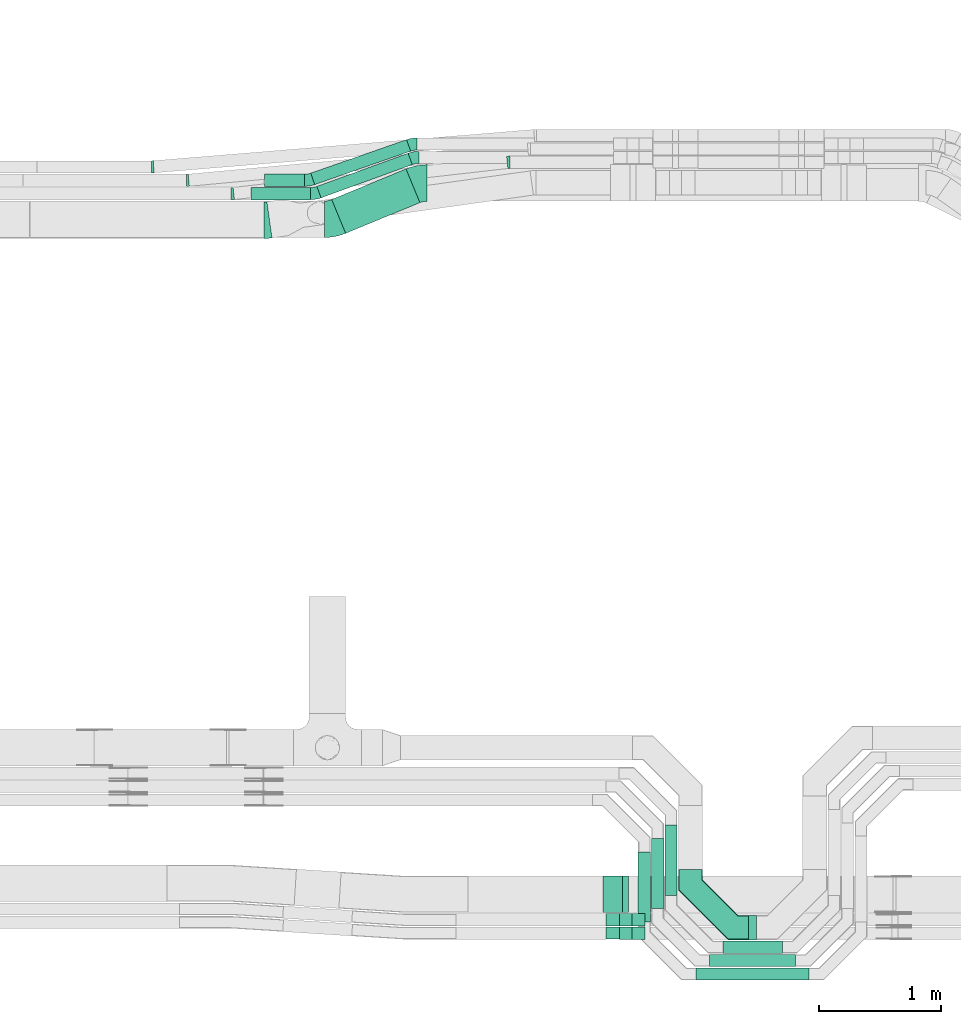
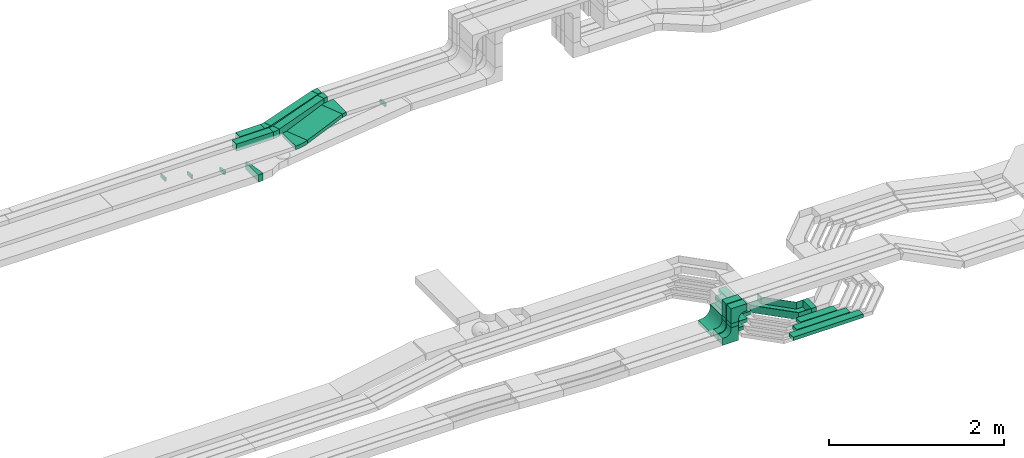
# One storey, part 13 of 32: 17 flow fittings, 15 flow segments.
"""IFC2X3 building model written with IfcOpenShell, lengths in millimetres."""

from ifc_helpers import new_model, entity, si_unit, converted_unit, derived_unit, direction, frame, frame_2d, origin, origin_2d_with_axis, place, context, subcontext, project, spatial, polyline, circle_curve, parameter, trimmed, segment, composite_curve, rectangle, outline, extrude, faceted_brep, source, transform, mapped, material, type_object, type_shapes, element, save


model = new_model("IFC2X3")

# Units and contexts
model_context = context("Model", 3, precision=0.01, world=origin(), true_north=direction((6.12303176911189e-17, 1.0)))
body_context = subcontext(model_context, "Body", "Model", "MODEL_VIEW")
ifc_project = project(units=[si_unit("LENGTHUNIT", "METRE", prefix="MILLI"), si_unit("AREAUNIT", "SQUARE_METRE"), si_unit("VOLUMEUNIT", "CUBIC_METRE"), converted_unit("PLANEANGLEUNIT", "DEGREE", entity("IfcRatioMeasure", 0.0174532925199433), si_unit("PLANEANGLEUNIT", "RADIAN"), dimensions=[0, 0, 0, 0, 0, 0, 0]), si_unit("MASSUNIT", "GRAM", prefix="KILO"), derived_unit("MASSDENSITYUNIT", [(si_unit("MASSUNIT", "GRAM", prefix="KILO"), 1), (si_unit("LENGTHUNIT", "METRE"), -3)]), derived_unit("MOMENTOFINERTIAUNIT", [(si_unit("LENGTHUNIT", "METRE"), 4)]), si_unit("TIMEUNIT", "SECOND"), si_unit("FREQUENCYUNIT", "HERTZ"), si_unit("THERMODYNAMICTEMPERATUREUNIT", "DEGREE_CELSIUS"), derived_unit("THERMALTRANSMITTANCEUNIT", [(si_unit("MASSUNIT", "GRAM", prefix="KILO"), 1), (si_unit("THERMODYNAMICTEMPERATUREUNIT", "KELVIN"), -1), (si_unit("TIMEUNIT", "SECOND"), -3)]), derived_unit("VOLUMETRICFLOWRATEUNIT", [(si_unit("LENGTHUNIT", "METRE"), 3), (si_unit("TIMEUNIT", "SECOND"), -1)]), derived_unit("MASSFLOWRATEUNIT", [(si_unit("MASSUNIT", "GRAM", prefix="KILO"), 1), (si_unit("TIMEUNIT", "SECOND"), -1)]), derived_unit("ROTATIONALFREQUENCYUNIT", [(si_unit("TIMEUNIT", "SECOND"), -1)]), si_unit("ELECTRICCURRENTUNIT", "AMPERE"), si_unit("ELECTRICVOLTAGEUNIT", "VOLT"), si_unit("POWERUNIT", "WATT"), si_unit("FORCEUNIT", "NEWTON", prefix="KILO"), si_unit("ILLUMINANCEUNIT", "LUX"), si_unit("LUMINOUSFLUXUNIT", "LUMEN"), si_unit("LUMINOUSINTENSITYUNIT", "CANDELA"), derived_unit("USERDEFINED", [(si_unit("MASSUNIT", "GRAM", prefix="KILO"), -1), (si_unit("LENGTHUNIT", "METRE"), -2), (si_unit("TIMEUNIT", "SECOND"), 3), (si_unit("LUMINOUSFLUXUNIT", "LUMEN"), 1)]), derived_unit("LINEARVELOCITYUNIT", [(si_unit("LENGTHUNIT", "METRE"), 1), (si_unit("TIMEUNIT", "SECOND"), -1)]), si_unit("PRESSUREUNIT", "PASCAL"), derived_unit("USERDEFINED", [(si_unit("LENGTHUNIT", "METRE"), -2), (si_unit("MASSUNIT", "GRAM", prefix="KILO"), 1), (si_unit("TIMEUNIT", "SECOND"), -2)]), derived_unit("LINEARFORCEUNIT", [(si_unit("MASSUNIT", "GRAM", prefix="KILO"), 1), (si_unit("LENGTHUNIT", "METRE"), 1), (si_unit("TIMEUNIT", "SECOND"), -2), (si_unit("LENGTHUNIT", "METRE"), -1)]), derived_unit("PLANARFORCEUNIT", [(si_unit("MASSUNIT", "GRAM", prefix="KILO"), 1), (si_unit("LENGTHUNIT", "METRE"), 1), (si_unit("TIMEUNIT", "SECOND"), -2), (si_unit("LENGTHUNIT", "METRE"), -2)])], contexts=[model_context])

# Site, building, storey
site_placement = place(None, origin())
site = spatial("IfcSite", under=ifc_project, at=site_placement, CompositionType="ELEMENT")
building_placement = place(site_placement, origin())
building = spatial("IfcBuilding", under=site, at=building_placement, CompositionType="ELEMENT")
storey_placement = place(building_placement, frame((0.0, 0.0, 8100.0)))
storey = spatial("IfcBuildingStorey", under=building, at=storey_placement, CompositionType="ELEMENT", Elevation=8100.0)

# Flow segments
cable_carrier_segment_type = type_object("IfcCableCarrierSegmentType", PredefinedType="CABLETRAYSEGMENT")
flow_segment_1_placement = place(storey_placement, frame((27126.5, 14216.7, 2840.02)))
element("IfcFlowSegment", 1, at=flow_segment_1_placement, inside=storey, type_object=cable_carrier_segment_type, context=body_context, shape_type="SweptSolid", body=[
    extrude(rectangle(XDim=659.52836889801, YDim=299.999999999997, at=origin_2d_with_axis()), frame((362.05, 264.47, 0.0), z_axis=(0.0, 0.0, 1.0), x_axis=(-0.924356472691493, -0.381529961331139, 0.0)), (0.0, 0.0, 1.0), 50.0000000000016),
])
flow_segment_2_placement = place(storey_placement, frame((27004.82, 14507.73, 2840.0)))
element("IfcFlowSegment", 2, at=flow_segment_2_placement, inside=storey, type_object=cable_carrier_segment_type, context=body_context, shape_type="SweptSolid", body=[
    extrude(rectangle(XDim=797.077067377563, YDim=99.9999999999991, at=origin_2d_with_axis()), frame((391.57, 183.44, 0.0), z_axis=(0.0, 0.0, 1.0), x_axis=(-0.939555537595458, -0.342396541708164, 0.0)), (0.0, 0.0, 1.0), 99.9999999999989),
])
flow_segment_3_placement = place(storey_placement, frame((26954.31, 14616.58, 2840.0)))
element("IfcFlowSegment", 3, at=flow_segment_3_placement, inside=storey, type_object=cable_carrier_segment_type, context=body_context, shape_type="SweptSolid", body=[
    extrude(rectangle(XDim=833.426581075166, YDim=100.000000000001, at=origin_2d_with_axis()), frame((409.9, 184.58, 0.0), z_axis=(0.0, 0.0, 1.0), x_axis=(-0.944095363050818, -0.329672482118153, 0.0)), (0.0, 0.0, 1.0), 99.9999999999989),
])
flow_segment_4_placement = place(storey_placement, frame((26464.1, 14492.28, 2840.0)))
element("IfcFlowSegment", 4, at=flow_segment_4_placement, inside=storey, type_object=cable_carrier_segment_type, context=body_context, shape_type="SweptSolid", body=[
    extrude(rectangle(XDim=487.423298539587, YDim=99.9999999999989, at=origin_2d_with_axis()), frame((243.71, 50.0, 0.0)), (0.0, 0.0, 1.0), 99.9999999999989),
])
flow_segment_5_placement = place(storey_placement, frame((26574.1, 14602.28, 2840.0)))
element("IfcFlowSegment", 5, at=flow_segment_5_placement, inside=storey, type_object=cable_carrier_segment_type, context=body_context, shape_type="SweptSolid", body=[
    extrude(rectangle(XDim=328.814741691739, YDim=99.9999999999989, at=origin_2d_with_axis()), frame((164.41, 50.0, 0.0)), (0.0, 0.0, 1.0), 99.9999999999989),
])
flow_segment_6_placement = place(storey_placement, frame((30337.47, 8308.02, 2800.0)))
element("IfcFlowSegment", 6, at=flow_segment_6_placement, inside=storey, type_object=cable_carrier_segment_type, context=body_context, shape_type="SweptSolid", body=[
    extrude(rectangle(XDim=487.314922946357, YDim=100.000000000001, at=origin_2d_with_axis()), frame((243.66, 50.0, 0.0)), (0.0, 0.0, 1.0), 50.0000000000016),
])
flow_segment_7_placement = place(storey_placement, frame((30227.95, 8198.49, 2800.0)))
element("IfcFlowSegment", 7, at=flow_segment_7_placement, inside=storey, type_object=cable_carrier_segment_type, context=body_context, shape_type="SweptSolid", body=[
    extrude(rectangle(XDim=706.36163665698, YDim=99.9999999999989, at=origin_2d_with_axis()), frame((353.18, 50.0, 0.0)), (0.0, 0.0, 1.0), 50.0000000000016),
])
flow_segment_8_placement = place(storey_placement, frame((30117.95, 8088.49, 2800.0)))
element("IfcFlowSegment", 8, at=flow_segment_8_placement, inside=storey, type_object=cable_carrier_segment_type, context=body_context, shape_type="SweptSolid", body=[
    extrude(rectangle(XDim=926.361636657043, YDim=99.9999999999989, at=origin_2d_with_axis()), frame((463.18, 50.0, 0.0)), (0.0, 0.0, 1.0), 50.0000000000016),
])
flow_segment_9_placement = place(storey_placement, frame((30547.47, 8418.02, 2800.0)))
element("IfcFlowSegment", 9, at=flow_segment_9_placement, inside=storey, type_object=cable_carrier_segment_type, context=body_context, shape_type="SweptSolid", body=[
    extrude(rectangle(XDim=67.3149229463092, YDim=200.0, at=origin_2d_with_axis()), frame((33.66, 100.0, 0.0)), (0.0, 0.0, 1.0), 99.9999999999989),
])
flow_segment_10_placement = place(storey_placement, frame((29489.46, 8422.45, 2999.32)))
element("IfcFlowSegment", 10, at=flow_segment_10_placement, inside=storey, type_object=cable_carrier_segment_type, context=body_context, shape_type="SweptSolid", body=[
    extrude(rectangle(XDim=100.000000000001, YDim=100.000000000003, at=origin_2d_with_axis()), frame((50.0, 50.0, 0.0), z_axis=(0.0, 0.0, 1.0), x_axis=(0.0, 1.0, 0.0)), (0.0, 0.0, 1.0), 54.9788826680355),
])
flow_segment_11_placement = place(storey_placement, frame((29489.46, 8532.45, 2999.67)))
element("IfcFlowSegment", 11, at=flow_segment_11_placement, inside=storey, type_object=cable_carrier_segment_type, context=body_context, shape_type="SweptSolid", body=[
    extrude(rectangle(XDim=100.000000000001, YDim=100.000000000003, at=origin_2d_with_axis()), frame((50.0, 50.0, 0.0), z_axis=(0.0, 0.0, 1.0), x_axis=(0.0, 1.0, 0.0)), (0.0, 0.0, 1.0), 55.3479418970819),
])
flow_segment_12_placement = place(storey_placement, frame((29514.46, 8642.05, 3000.02)))
element("IfcFlowSegment", 12, at=flow_segment_12_placement, inside=storey, type_object=cable_carrier_segment_type, context=body_context, shape_type="SweptSolid", body=[
    extrude(rectangle(XDim=299.999999999999, YDim=49.9999999999973, at=origin_2d_with_axis()), frame((25.0, 150.0, 0.0), z_axis=(0.0, 0.0, 1.0), x_axis=(0.0, 1.0, 0.0)), (0.0, 0.0, 1.0), 5.00181141795619),
])
flow_segment_13_placement = place(storey_placement, frame((29861.47, 8784.02, 2800.0)))
element("IfcFlowSegment", 13, at=flow_segment_13_placement, inside=storey, type_object=cable_carrier_segment_type, context=body_context, shape_type="SweptSolid", body=[
    extrude(rectangle(XDim=574.980554870002, YDim=100.000000000003, at=origin_2d_with_axis()), frame((50.0, 287.49, 0.0), z_axis=(0.0, 0.0, 1.0), x_axis=(0.0, 1.0, 0.0)), (0.0, 0.0, 1.0), 50.0000000000016),
])
flow_segment_14_placement = place(storey_placement, frame((29751.95, 8674.49, 2800.0)))
element("IfcFlowSegment", 14, at=flow_segment_14_placement, inside=storey, type_object=cable_carrier_segment_type, context=body_context, shape_type="SweptSolid", body=[
    extrude(rectangle(XDim=574.980554869993, YDim=100.000000000003, at=origin_2d_with_axis()), frame((50.0, 287.49, 0.0), z_axis=(0.0, 0.0, 1.0), x_axis=(0.0, 1.0, 0.0)), (0.0, 0.0, 1.0), 50.0000000000016),
])
flow_segment_15_placement = place(storey_placement, frame((29641.95, 8564.49, 2800.0)))
element("IfcFlowSegment", 15, at=flow_segment_15_placement, inside=storey, type_object=cable_carrier_segment_type, context=body_context, shape_type="SweptSolid", body=[
    extrude(rectangle(XDim=574.98055487001, YDim=100.000000000003, at=origin_2d_with_axis()), frame((50.0, 287.49, 0.0), z_axis=(0.0, 0.0, 1.0), x_axis=(0.0, 1.0, 0.0)), (0.0, 0.0, 1.0), 50.0000000000016),
])

# Flow fittings
ifc_material = material()
cable_carrier_fitting_type_1 = type_object("IfcCableCarrierFittingType", Name="470_DKC_G5_Sheet horizontal bend:-", PredefinedType="NOTDEFINED", material=ifc_material)
shared_shape_1 = source(origin(), body_context, "Body", "Brep", [
    faceted_brep([(-476.0, -100.0, -50.0), (-476.0, -100.0, 50.0), (-476.0, -95.0, 50.0), (-476.0, -95.0, -45.0), (-476.0, 95.0, -45.0), (-476.0, 95.0, 50.0), (-476.0, 100.0, 50.0), (-476.0, 100.0, -50.0), (100.0, 476.0, -50.0), (-100.0, 476.0, -50.0), (-100.0, 476.0, 50.0), (-95.0, 476.0, 50.0), (-95.0, 476.0, -45.0), (95.0, 476.0, -45.0), (95.0, 476.0, 50.0), (100.0, 476.0, 50.0), (-308.58, -100.0, -50.0), (-308.58, -100.0, 50.0), (100.0, 308.58, 50.0), (95.0, 310.65, 50.0), (-310.65, -95.0, 50.0), (-310.65, -95.0, -45.0), (95.0, 310.65, -45.0), (-95.0, 389.35, -45.0), (-389.35, 95.0, -45.0), (-389.35, 95.0, 50.0), (-95.0, 389.35, 50.0), (-100.0, 391.42, 50.0), (-391.42, 100.0, 50.0), (-391.42, 100.0, -50.0), (-100.0, 391.42, -50.0), (100.0, 308.58, -50.0)], [[[0, 1, 2, 3, 4, 5, 6, 7]], [[8, 9, 10, 11, 12, 13, 14, 15]], [[1, 0, 16, 17]], [[2, 1, 17, 18, 15, 14, 19, 20]], [[3, 2, 20, 21]], [[4, 3, 21, 22, 13, 12, 23, 24]], [[5, 4, 24, 25]], [[6, 5, 25, 26, 11, 10, 27, 28]], [[7, 6, 28, 29]], [[0, 7, 29, 30, 9, 8, 31, 16]], [[17, 16, 31, 18]], [[21, 20, 19, 22]], [[25, 24, 23, 26]], [[29, 28, 27, 30]], [[18, 31, 8, 15]], [[22, 19, 14, 13]], [[26, 23, 12, 11]], [[30, 27, 10, 9]]]),
])
type_shapes(cable_carrier_fitting_type_1, [shared_shape_1])
flow_fitting_1_placement = place(storey_placement, frame((30071.47, 8518.02, 2850.0), z_axis=(0.0, 0.0, 1.0), x_axis=(0.0, -1.0, 0.0)))
element("IfcFlowFitting", 16, at=flow_fitting_1_placement, inside=storey, type_object=cable_carrier_fitting_type_1, material=ifc_material, Name="470_DKC_G5_Sheet horizontal bend:-", ObjectType="470_DKC_G5_Sheet horizontal bend:-", context=body_context, shape_type="MappedRepresentation", body=[
    mapped(shared_shape_1, transform((0.0, 0.0, 0.0), scale=1.0)),
])
cable_carrier_fitting_type_2 = type_object("IfcCableCarrierFittingType", Name="470_DKC_S5_CDV 90 external vertical angle:-", PredefinedType="NOTDEFINED", material=ifc_material)
shared_shape_2 = source(origin(), body_context, "Body", "SweptSolid", [
    extrude(outline(composite_curve([segment(polyline([(65.71, 14.29), (95.71, 14.29)]), True, "CONTINUOUS"), segment(polyline([(95.71, 14.29), (95.71, 114.29)]), True, "CONTINUOUS"), segment(polyline([(95.71, 114.29), (-114.29, 114.29)]), True, "CONTINUOUS"), segment(polyline([(-114.29, 114.29), (-114.29, -95.71)]), True, "CONTINUOUS"), segment(polyline([(-114.29, -95.71), (-14.29, -95.71)]), True, "CONTINUOUS"), segment(polyline([(-14.29, -95.71), (-14.29, -65.71)]), True, "CONTINUOUS"), segment(trimmed(circle_curve(frame_2d((65.71, -65.71), x_axis=(-1.0, 0.0)), 80.0), [parameter(270.0)], [parameter(2.54444374517082e-13)], True, "PARAMETER"), False, "CONTINUOUS")], self_intersect=False)), frame((-64.29, 64.29, -49.0), z_axis=(0.0, 0.0, 1.0), x_axis=(-1.0, 0.0, 0.0)), (0.0, 0.0, 1.0), 99.0000000000002),
])
type_shapes(cable_carrier_fitting_type_2, [shared_shape_2])
for number, where, z_axis, x_axis, name in (
    (17, (29539.46, 8472.45, 3214.3), (0.0, -1.0, 0.0), (-1.0, 0.0, 0.0), "470_DKC_S5_90 external vertical angle"),
    (18, (29539.46, 8582.45, 3215.02), (0.0, 1.0, 0.0), (0.0, 0.0, 1.0), "470_DKC_S5_90 external vertical angle"),
):
    element("IfcFlowFitting", number, at=place(storey_placement, frame(where, z_axis=z_axis, x_axis=x_axis)), inside=storey, type_object=cable_carrier_fitting_type_2, material=ifc_material, Name=name, ObjectType="470_DKC_S5_CDV 90 external vertical angle:-", context=body_context, shape_type="MappedRepresentation", body=[
        mapped(shared_shape_2, transform((0.0, 0.0, 0.0), scale=1.0)),
    ])
cable_carrier_fitting_type_3 = type_object("IfcCableCarrierFittingType", Name="470_DKC_S5_CDV 90 external vertical angle:-", PredefinedType="NOTDEFINED", material=ifc_material)
type_shapes(cable_carrier_fitting_type_3, [shared_shape_2])
for number, where, z_axis, x_axis, name in (
    (19, (29539.46, 8582.45, 2839.67), (0.0, 1.0, 0.0), (0.0, 0.0, -1.0), "470_DKC_S5_90 external vertical angle"),
    (20, (29539.46, 8472.45, 2839.32), (0.0, 1.0, 0.0), (0.0, 0.0, -1.0), "470_DKC_S5_90 external vertical angle"),
):
    element("IfcFlowFitting", number, at=place(storey_placement, frame(where, z_axis=z_axis, x_axis=x_axis)), inside=storey, type_object=cable_carrier_fitting_type_3, material=ifc_material, Name=name, ObjectType="470_DKC_S5_CDV 90 external vertical angle:-", context=body_context, shape_type="MappedRepresentation", body=[
        mapped(shared_shape_2, transform((0.0, 0.0, 0.0), scale=1.0)),
    ])
cable_carrier_fitting_type_4 = type_object("IfcCableCarrierFittingType", Name="470_DKC_S5_CDV 90 external vertical angle:-", PredefinedType="NOTDEFINED", material=ifc_material)
shared_shape_3 = source(origin(), body_context, "Body", "SweptSolid", [
    extrude(outline(composite_curve([segment(polyline([(80.0, 50.0), (110.0, 50.0)]), True, "CONTINUOUS"), segment(polyline([(110.0, 50.0), (110.0, 100.0)]), True, "CONTINUOUS"), segment(polyline([(110.0, 100.0), (-100.0, 100.0)]), True, "CONTINUOUS"), segment(polyline([(-100.0, 100.0), (-100.0, -110.0)]), True, "CONTINUOUS"), segment(polyline([(-100.0, -110.0), (-50.0, -110.0)]), True, "CONTINUOUS"), segment(polyline([(-50.0, -110.0), (-50.0, -80.0)]), True, "CONTINUOUS"), segment(trimmed(circle_curve(frame_2d((80.0, -80.0), x_axis=(-1.0, 0.0)), 130.0), [parameter(270.0)], [parameter(2.54444374517082e-13)], True, "PARAMETER"), False, "CONTINUOUS")], self_intersect=False)), frame((-75.0, 75.0, -149.0), z_axis=(0.0, 0.0, 1.0), x_axis=(-1.0, 0.0, 0.0)), (0.0, 0.0, 1.0), 299.0),
])
type_shapes(cable_carrier_fitting_type_4, [shared_shape_3])
flow_fitting_2_placement = place(storey_placement, frame((29539.46, 8792.05, 2815.02), z_axis=(0.0, 1.0, 0.0), x_axis=(0.0, 0.0, -1.0)))
element("IfcFlowFitting", 21, at=flow_fitting_2_placement, inside=storey, type_object=cable_carrier_fitting_type_4, material=ifc_material, Name="470_DKC_S5_90 external vertical angle", ObjectType="470_DKC_S5_CDV 90 external vertical angle:-", context=body_context, shape_type="MappedRepresentation", body=[
    mapped(shared_shape_3, transform((0.0, 0.0, 0.0), scale=1.0)),
])
cable_carrier_fitting_type_5 = type_object("IfcCableCarrierFittingType", Name="470_DKC_S5_Variable Angle Elbow 0-45:-", PredefinedType="NOTDEFINED", material=ifc_material)
shared_shape_4 = source(origin(), body_context, "Body", "SweptSolid", [
    extrude(outline(composite_curve([segment(polyline([(-12.29, -50.67), (-11.29, -50.67)]), True, "CONTINUOUS"), segment(trimmed(circle_curve(frame_2d((-11.29, 199.33), x_axis=(0.0, -1.0)), 250.0), [parameter(0.0)], [parameter(6.48278712085122)], True, "PARAMETER"), True, "CONTINUOUS"), segment(polyline([(16.94, -49.07), (17.93, -48.96)]), True, "CONTINUOUS"), segment(polyline([(17.93, -48.96), (6.64, 50.4)]), True, "CONTINUOUS"), segment(polyline([(6.64, 50.4), (5.65, 50.29)]), True, "CONTINUOUS"), segment(trimmed(circle_curve(frame_2d((-11.29, 199.33), x_axis=(0.0, -1.0)), 150.0), [parameter(0.0)], [parameter(6.48278712085122)], True, "PARAMETER"), False, "CONTINUOUS"), segment(polyline([(-11.29, 49.33), (-12.29, 49.33)]), True, "CONTINUOUS"), segment(polyline([(-12.29, 49.33), (-12.29, -50.67)]), True, "CONTINUOUS")], self_intersect=False)), frame((-0.04, 0.67, -25.0)), (0.0, 0.0, 1.0), 50.0000000000002),
])
type_shapes(cable_carrier_fitting_type_5, [shared_shape_4])
flow_fitting_3_placement = place(storey_placement, frame((28579.36, 14800.06, 2590.34), z_axis=(0.0, 0.0, 1.0), x_axis=(-1.0, 0.0, 0.0)))
element("IfcFlowFitting", 22, at=flow_fitting_3_placement, inside=storey, type_object=cable_carrier_fitting_type_5, material=ifc_material, Name="470_DKC_S5_Variable Angle Elbow 0-45:-", ObjectType="470_DKC_S5_Variable Angle Elbow 0-45:-", context=body_context, shape_type="MappedRepresentation", body=[
    mapped(shared_shape_4, transform((0.0, 0.0, 0.0), scale=1.0)),
])
flow_fitting_4_placement = place(storey_placement, frame((26310.81, 14542.28, 2590.34)))
element("IfcFlowFitting", 23, at=flow_fitting_4_placement, inside=storey, type_object=cable_carrier_fitting_type_5, material=ifc_material, Name="470_DKC_S5_Variable Angle Elbow 0-45:-", ObjectType="470_DKC_S5_Variable Angle Elbow 0-45:-", context=body_context, shape_type="MappedRepresentation", body=[
    mapped(shared_shape_4, transform((0.0, 0.0, 0.0), scale=1.0)),
])
cable_carrier_fitting_type_6 = type_object("IfcCableCarrierFittingType", Name="470_DKC_S5_Variable Angle Elbow 0-45:-", PredefinedType="NOTDEFINED", material=ifc_material)
shared_shape_5 = source(origin(), body_context, "Body", "SweptSolid", [
    extrude(outline(composite_curve([segment(polyline([(-10.16, -50.44), (-9.16, -50.44)]), True, "CONTINUOUS"), segment(trimmed(circle_curve(frame_2d((-9.16, 199.56), x_axis=(0.0, -1.0)), 250.0), [parameter(0.0)], [parameter(5.25373463552036)], True, "PARAMETER"), True, "CONTINUOUS"), segment(polyline([(13.74, -49.39), (14.73, -49.3)]), True, "CONTINUOUS"), segment(polyline([(14.73, -49.3), (5.58, 50.28)]), True, "CONTINUOUS"), segment(polyline([(5.58, 50.28), (4.58, 50.19)]), True, "CONTINUOUS"), segment(trimmed(circle_curve(frame_2d((-9.16, 199.56), x_axis=(0.0, -1.0)), 150.0), [parameter(0.0)], [parameter(5.25373463552036)], True, "PARAMETER"), False, "CONTINUOUS"), segment(polyline([(-9.16, 49.56), (-10.16, 49.56)]), True, "CONTINUOUS"), segment(polyline([(-10.16, 49.56), (-10.16, -50.44)]), True, "CONTINUOUS")], self_intersect=False)), frame((-0.02, 0.44, -25.0)), (0.0, 0.0, 1.0), 50.0000000000002),
])
type_shapes(cable_carrier_fitting_type_6, [shared_shape_5])
flow_fitting_5_placement = place(storey_placement, frame((25943.41, 14652.28, 2595.0)))
element("IfcFlowFitting", 24, at=flow_fitting_5_placement, inside=storey, type_object=cable_carrier_fitting_type_6, material=ifc_material, Name="470_DKC_S5_Variable Angle Elbow 0-45:-", ObjectType="470_DKC_S5_Variable Angle Elbow 0-45:-", context=body_context, shape_type="MappedRepresentation", body=[
    mapped(shared_shape_5, transform((0.0, 0.0, 0.0), scale=1.0)),
])
cable_carrier_fitting_type_7 = type_object("IfcCableCarrierFittingType", Name="470_DKC_S5_Variable Angle Elbow 0-45:-", PredefinedType="NOTDEFINED", material=ifc_material)
shared_shape_6 = source(origin(), body_context, "Body", "SweptSolid", [
    extrude(outline(composite_curve([segment(polyline([(-9.18, -50.36), (-8.18, -50.36)]), True, "CONTINUOUS"), segment(trimmed(circle_curve(frame_2d((-8.18, 199.64), x_axis=(0.0, -1.0)), 250.0), [parameter(0.0)], [parameter(4.69132642007995)], True, "PARAMETER"), True, "CONTINUOUS"), segment(polyline([(12.27, -49.52), (13.27, -49.44)]), True, "CONTINUOUS"), segment(polyline([(13.27, -49.44), (5.09, 50.23)]), True, "CONTINUOUS"), segment(polyline([(5.09, 50.23), (4.09, 50.15)]), True, "CONTINUOUS"), segment(trimmed(circle_curve(frame_2d((-8.18, 199.64), x_axis=(0.0, -1.0)), 150.0), [parameter(0.0)], [parameter(4.69132642007995)], True, "PARAMETER"), False, "CONTINUOUS"), segment(polyline([(-8.18, 49.64), (-9.18, 49.64)]), True, "CONTINUOUS"), segment(polyline([(-9.18, 49.64), (-9.18, -50.36)]), True, "CONTINUOUS")], self_intersect=False)), frame((-0.01, 0.36, -25.0)), (0.0, 0.0, 1.0), 50.0000000000002),
])
type_shapes(cable_carrier_fitting_type_7, [shared_shape_6])
flow_fitting_6_placement = place(storey_placement, frame((25656.77, 14762.28, 2595.0)))
element("IfcFlowFitting", 25, at=flow_fitting_6_placement, inside=storey, type_object=cable_carrier_fitting_type_7, material=ifc_material, Name="470_DKC_S5_Variable Angle Elbow 0-45:-", ObjectType="470_DKC_S5_Variable Angle Elbow 0-45:-", context=body_context, shape_type="MappedRepresentation", body=[
    mapped(shared_shape_6, transform((0.0, 0.0, 0.0), scale=1.0)),
])
cable_carrier_fitting_type_8 = type_object("IfcCableCarrierFittingType", Name="470_DKC_S5_Variable Angle Elbow 0-45:-", PredefinedType="NOTDEFINED", material=ifc_material)
shared_shape_7 = source(origin(), body_context, "Body", "SweptSolid", [
    extrude(outline(composite_curve([segment(polyline([(-58.21, -161.44), (-57.21, -161.44)]), True, "CONTINUOUS"), segment(trimmed(circle_curve(frame_2d((-57.21, 288.56), x_axis=(0.0, -1.0)), 450.0), [parameter(0.0)], [parameter(22.4284842268306)], True, "PARAMETER"), True, "CONTINUOUS"), segment(polyline([(114.48, -127.4), (115.4, -127.02)]), True, "CONTINUOUS"), segment(polyline([(115.4, -127.02), (0.94, 150.29)]), True, "CONTINUOUS"), segment(polyline([(0.94, 150.29), (0.02, 149.9)]), True, "CONTINUOUS"), segment(trimmed(circle_curve(frame_2d((-57.21, 288.56), x_axis=(0.0, -1.0)), 150.0), [parameter(0.0)], [parameter(22.4284842268306)], True, "PARAMETER"), False, "CONTINUOUS"), segment(polyline([(-57.21, 138.56), (-58.21, 138.56)]), True, "CONTINUOUS"), segment(polyline([(-58.21, 138.56), (-58.21, -161.44)]), True, "CONTINUOUS")], self_intersect=False)), frame((-2.27, 11.44, -25.0)), (0.0, 0.0, 1.0), 49.9999999999992),
])
type_shapes(cable_carrier_fitting_type_8, [shared_shape_7])
flow_fitting_7_placement = place(storey_placement, frame((27849.28, 14630.06, 2865.02), z_axis=(0.0, 0.0, 1.0), x_axis=(-1.0, 0.0, 0.0)))
element("IfcFlowFitting", 26, at=flow_fitting_7_placement, inside=storey, type_object=cable_carrier_fitting_type_8, material=ifc_material, Name="470_DKC_S5_Variable Angle Elbow 0-45:-", ObjectType="470_DKC_S5_Variable Angle Elbow 0-45:-", context=body_context, shape_type="MappedRepresentation", body=[
    mapped(shared_shape_7, transform((0.0, 0.0, 0.0), scale=1.0)),
])
flow_fitting_8_placement = place(storey_placement, frame((27127.83, 14332.28, 2865.02)))
element("IfcFlowFitting", 27, at=flow_fitting_8_placement, inside=storey, type_object=cable_carrier_fitting_type_8, material=ifc_material, Name="470_DKC_S5_Variable Angle Elbow 0-45:-", ObjectType="470_DKC_S5_Variable Angle Elbow 0-45:-", context=body_context, shape_type="MappedRepresentation", body=[
    mapped(shared_shape_7, transform((0.0, 0.0, 0.0), scale=1.0)),
])
cable_carrier_fitting_type_9 = type_object("IfcCableCarrierFittingType", Name="470_DKC_S5_Variable Angle Elbow 0-45:-", PredefinedType="NOTDEFINED", material=ifc_material)
shared_shape_8 = source(origin(), body_context, "Body", "SweptSolid", [
    extrude(outline(composite_curve([segment(polyline([(-35.22, -56.13), (-34.22, -56.13)]), True, "CONTINUOUS"), segment(trimmed(circle_curve(frame_2d((-34.22, 193.87), x_axis=(0.0, -1.0)), 250.0), [parameter(0.0)], [parameter(20.0229517728653)], True, "PARAMETER"), True, "CONTINUOUS"), segment(polyline([(51.37, -41.02), (52.31, -40.68)]), True, "CONTINUOUS"), segment(polyline([(52.31, -40.68), (18.07, 53.28)]), True, "CONTINUOUS"), segment(polyline([(18.07, 53.28), (17.13, 52.94)]), True, "CONTINUOUS"), segment(trimmed(circle_curve(frame_2d((-34.22, 193.87), x_axis=(0.0, -1.0)), 150.0), [parameter(0.0)], [parameter(20.0229517728653)], True, "PARAMETER"), False, "CONTINUOUS"), segment(polyline([(-34.22, 43.87), (-35.22, 43.87)]), True, "CONTINUOUS"), segment(polyline([(-35.22, 43.87), (-35.22, -56.13)]), True, "CONTINUOUS")], self_intersect=False)), frame((-1.08, 6.13, -50.0)), (0.0, 0.0, 1.0), 100.0),
])
type_shapes(cable_carrier_fitting_type_9, [shared_shape_8])
flow_fitting_9_placement = place(storey_placement, frame((27804.95, 14840.06, 2890.0), z_axis=(0.0, 0.0, 1.0), x_axis=(-1.0, 0.0, 0.0)))
element("IfcFlowFitting", 28, at=flow_fitting_9_placement, inside=storey, type_object=cable_carrier_fitting_type_9, material=ifc_material, Name="470_DKC_S5_Variable Angle Elbow 0-45:-", ObjectType="470_DKC_S5_Variable Angle Elbow 0-45:-", context=body_context, shape_type="MappedRepresentation", body=[
    mapped(shared_shape_8, transform((0.0, 0.0, 0.0), scale=1.0)),
])
flow_fitting_10_placement = place(storey_placement, frame((26987.83, 14542.28, 2890.0)))
element("IfcFlowFitting", 29, at=flow_fitting_10_placement, inside=storey, type_object=cable_carrier_fitting_type_9, material=ifc_material, Name="470_DKC_S5_Variable Angle Elbow 0-45:-", ObjectType="470_DKC_S5_Variable Angle Elbow 0-45:-", context=body_context, shape_type="MappedRepresentation", body=[
    mapped(shared_shape_8, transform((0.0, 0.0, 0.0), scale=1.0)),
])
cable_carrier_fitting_type_10 = type_object("IfcCableCarrierFittingType", Name="470_DKC_S5_Variable Angle Elbow 0-45:-", PredefinedType="NOTDEFINED", material=ifc_material)
shared_shape_9 = source(origin(), body_context, "Body", "SweptSolid", [
    extrude(outline(composite_curve([segment(polyline([(-33.95, -55.67), (-32.95, -55.67)]), True, "CONTINUOUS"), segment(trimmed(circle_curve(frame_2d((-32.95, 194.33), x_axis=(0.0, -1.0)), 250.0), [parameter(0.0)], [parameter(19.2488977013697)], True, "PARAMETER"), True, "CONTINUOUS"), segment(polyline([(49.46, -41.7), (50.41, -41.37)]), True, "CONTINUOUS"), segment(polyline([(50.41, -41.37), (17.44, 53.04)]), True, "CONTINUOUS"), segment(polyline([(17.44, 53.04), (16.5, 52.71)]), True, "CONTINUOUS"), segment(trimmed(circle_curve(frame_2d((-32.95, 194.33), x_axis=(0.0, -1.0)), 150.0), [parameter(0.0)], [parameter(19.2488977013697)], True, "PARAMETER"), False, "CONTINUOUS"), segment(polyline([(-32.95, 44.33), (-33.95, 44.33)]), True, "CONTINUOUS"), segment(polyline([(-33.95, 44.33), (-33.95, -55.67)]), True, "CONTINUOUS")], self_intersect=False)), frame((-0.96, 5.67, -50.0)), (0.0, 0.0, 1.0), 100.0),
])
type_shapes(cable_carrier_fitting_type_10, [shared_shape_9])
flow_fitting_11_placement = place(storey_placement, frame((27790.59, 14950.06, 2890.0), z_axis=(0.0, 0.0, 1.0), x_axis=(-1.0, 0.0, 0.0)))
element("IfcFlowFitting", 30, at=flow_fitting_11_placement, inside=storey, type_object=cable_carrier_fitting_type_10, material=ifc_material, Name="470_DKC_S5_Variable Angle Elbow 0-45:-", ObjectType="470_DKC_S5_Variable Angle Elbow 0-45:-", context=body_context, shape_type="MappedRepresentation", body=[
    mapped(shared_shape_9, transform((0.0, 0.0, 0.0), scale=1.0)),
])
flow_fitting_12_placement = place(storey_placement, frame((26937.83, 14652.28, 2890.0)))
element("IfcFlowFitting", 31, at=flow_fitting_12_placement, inside=storey, type_object=cable_carrier_fitting_type_10, material=ifc_material, Name="470_DKC_S5_Variable Angle Elbow 0-45:-", ObjectType="470_DKC_S5_Variable Angle Elbow 0-45:-", context=body_context, shape_type="MappedRepresentation", body=[
    mapped(shared_shape_9, transform((0.0, 0.0, 0.0), scale=1.0)),
])
cable_carrier_fitting_type_11 = type_object("IfcCableCarrierFittingType", Name="470_DKC_S5_Variable Angle Elbow 0-45:-", PredefinedType="NOTDEFINED", material=ifc_material)
shared_shape_10 = source(origin(), body_context, "Body", "SweptSolid", [
    extrude(outline(composite_curve([segment(polyline([(-21.85, -151.49), (-20.85, -151.49)]), True, "CONTINUOUS"), segment(trimmed(circle_curve(frame_2d((-20.85, 298.51), x_axis=(0.0, -1.0)), 450.0), [parameter(0.0)], [parameter(7.99024953505022)], True, "PARAMETER"), True, "CONTINUOUS"), segment(polyline([(41.7, -147.12), (42.69, -146.98)]), True, "CONTINUOUS"), segment(polyline([(42.69, -146.98), (0.99, 150.1)]), True, "CONTINUOUS"), segment(polyline([(0.99, 150.1), (0.0, 149.97)]), True, "CONTINUOUS"), segment(trimmed(circle_curve(frame_2d((-20.85, 298.51), x_axis=(0.0, -1.0)), 150.0), [parameter(0.0)], [parameter(7.99024953505022)], True, "PARAMETER"), False, "CONTINUOUS"), segment(polyline([(-20.85, 148.51), (-21.85, 148.51)]), True, "CONTINUOUS"), segment(polyline([(-21.85, 148.51), (-21.85, -151.49)]), True, "CONTINUOUS")], self_intersect=False)), frame((-0.1, 1.49, -50.0)), (0.0, 0.0, 1.0), 99.9999999999997),
])
type_shapes(cable_carrier_fitting_type_11, [shared_shape_10])
flow_fitting_13_placement = place(storey_placement, frame((26594.05, 14324.5, 2615.0)))
element("IfcFlowFitting", 32, at=flow_fitting_13_placement, inside=storey, type_object=cable_carrier_fitting_type_11, material=ifc_material, Name="470_DKC_S5_Variable Angle Elbow 0-45:-", ObjectType="470_DKC_S5_Variable Angle Elbow 0-45:-", context=body_context, shape_type="MappedRepresentation", body=[
    mapped(shared_shape_10, transform((0.0, 0.0, 0.0), scale=1.0)),
])

save(model, "model.ifc")
